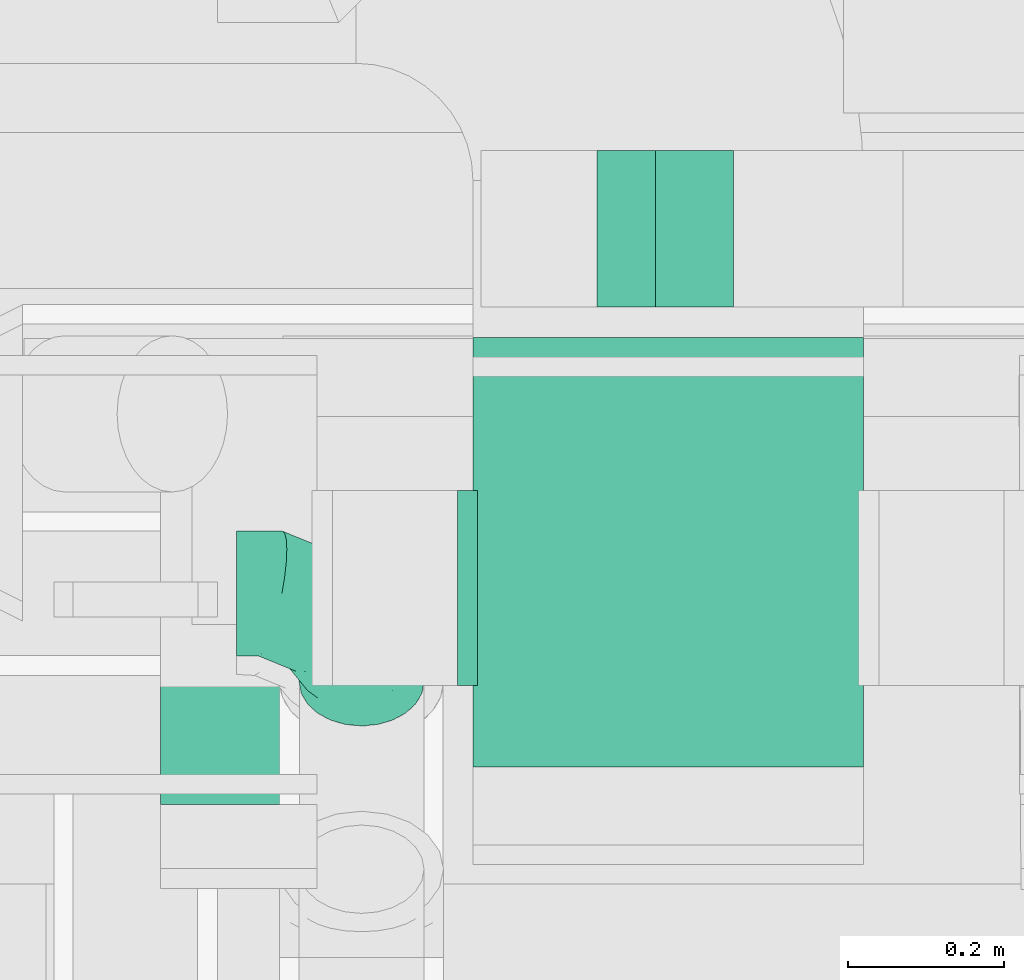
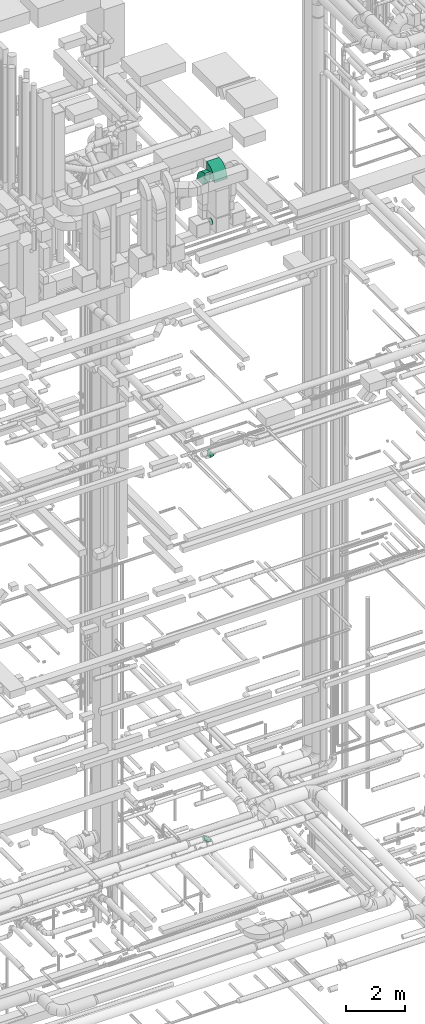
# One storey, part 233 of 337: 5 flow fittings.
"""IFC2X3 building model written with IfcOpenShell, lengths in millimetres."""

from ifc_helpers import new_model, entity, si_unit, converted_unit, derived_unit, direction, frame, frame_2d, origin, place, context, subcontext, project, spatial, polyline, circle_curve, parameter, trimmed, segment, composite_curve, outline, extrude, faceted_brep, source, transform, mapped, material, type_object, type_shapes, element, save


model = new_model("IFC2X3")

# Units and contexts
model_context = context("Model", 3, precision=0.01, world=origin(), true_north=direction((6.12303176911189e-17, 1.0)))
body_context = subcontext(model_context, "Body", "Model", "MODEL_VIEW")
ifc_project = project(units=[si_unit("LENGTHUNIT", "METRE", prefix="MILLI"), si_unit("AREAUNIT", "SQUARE_METRE"), si_unit("VOLUMEUNIT", "CUBIC_METRE"), converted_unit("PLANEANGLEUNIT", "DEGREE", entity("IfcRatioMeasure", 0.0174532925199433), si_unit("PLANEANGLEUNIT", "RADIAN"), dimensions=[0, 0, 0, 0, 0, 0, 0]), si_unit("MASSUNIT", "GRAM", prefix="KILO"), derived_unit("MASSDENSITYUNIT", [(si_unit("MASSUNIT", "GRAM", prefix="KILO"), 1), (si_unit("LENGTHUNIT", "METRE"), -3)]), derived_unit("MOMENTOFINERTIAUNIT", [(si_unit("LENGTHUNIT", "METRE"), 4)]), si_unit("TIMEUNIT", "SECOND"), si_unit("FREQUENCYUNIT", "HERTZ"), si_unit("THERMODYNAMICTEMPERATUREUNIT", "DEGREE_CELSIUS"), derived_unit("THERMALTRANSMITTANCEUNIT", [(si_unit("MASSUNIT", "GRAM", prefix="KILO"), 1), (si_unit("THERMODYNAMICTEMPERATUREUNIT", "KELVIN"), -1), (si_unit("TIMEUNIT", "SECOND"), -3)]), derived_unit("VOLUMETRICFLOWRATEUNIT", [(si_unit("LENGTHUNIT", "METRE"), 3), (si_unit("TIMEUNIT", "SECOND"), -1)]), derived_unit("MASSFLOWRATEUNIT", [(si_unit("MASSUNIT", "GRAM", prefix="KILO"), 1), (si_unit("TIMEUNIT", "SECOND"), -1)]), derived_unit("ROTATIONALFREQUENCYUNIT", [(si_unit("TIMEUNIT", "SECOND"), -1)]), si_unit("ELECTRICCURRENTUNIT", "AMPERE"), si_unit("ELECTRICVOLTAGEUNIT", "VOLT"), si_unit("POWERUNIT", "WATT"), si_unit("FORCEUNIT", "NEWTON", prefix="KILO"), si_unit("ILLUMINANCEUNIT", "LUX"), si_unit("LUMINOUSFLUXUNIT", "LUMEN"), si_unit("LUMINOUSINTENSITYUNIT", "CANDELA"), derived_unit("USERDEFINED", [(si_unit("MASSUNIT", "GRAM", prefix="KILO"), -1), (si_unit("LENGTHUNIT", "METRE"), -2), (si_unit("TIMEUNIT", "SECOND"), 3), (si_unit("LUMINOUSFLUXUNIT", "LUMEN"), 1)]), derived_unit("LINEARVELOCITYUNIT", [(si_unit("LENGTHUNIT", "METRE"), 1), (si_unit("TIMEUNIT", "SECOND"), -1)]), si_unit("PRESSUREUNIT", "PASCAL"), derived_unit("USERDEFINED", [(si_unit("LENGTHUNIT", "METRE"), -2), (si_unit("MASSUNIT", "GRAM", prefix="KILO"), 1), (si_unit("TIMEUNIT", "SECOND"), -2)]), derived_unit("LINEARFORCEUNIT", [(si_unit("MASSUNIT", "GRAM", prefix="KILO"), 1), (si_unit("LENGTHUNIT", "METRE"), 1), (si_unit("TIMEUNIT", "SECOND"), -2), (si_unit("LENGTHUNIT", "METRE"), -1)]), derived_unit("PLANARFORCEUNIT", [(si_unit("MASSUNIT", "GRAM", prefix="KILO"), 1), (si_unit("LENGTHUNIT", "METRE"), 1), (si_unit("TIMEUNIT", "SECOND"), -2), (si_unit("LENGTHUNIT", "METRE"), -2)])], contexts=[model_context])

# Site, building, storey
site_placement = place(None, origin())
site = spatial("IfcSite", under=ifc_project, at=site_placement, CompositionType="ELEMENT")
building_placement = place(site_placement, origin())
building = spatial("IfcBuilding", under=site, at=building_placement, CompositionType="ELEMENT")
storey_placement = place(building_placement, origin())
storey = spatial("IfcBuildingStorey", under=building, at=storey_placement, CompositionType="ELEMENT", Elevation=0.0)

# Flow fittings
ifc_material = material()
duct_fitting_type_1 = type_object("IfcDuctFittingType", PredefinedType="NOTDEFINED", material=ifc_material)
shared_shape_1 = source(origin(), body_context, "Body", "Brep", [
    faceted_brep([(-160.0, 0.0, -80.0), (-160.0, -20.71, -77.27), (-160.0, -40.0, -69.28), (-160.0, -56.57, -56.57), (-160.0, -69.28, -40.0), (-160.0, -77.27, -20.71), (-160.0, -80.0, 0.0), (-160.0, -77.27, 20.71), (-160.0, -69.28, 40.0), (-160.0, -56.57, 56.57), (-160.0, -40.0, 69.28), (-160.0, -20.71, 77.27), (-160.0, 0.0, 80.0), (-160.0, 20.71, 77.27), (-160.0, 40.0, 69.28), (-160.0, 56.57, 56.57), (-160.0, 69.28, 40.0), (-160.0, 77.27, 20.71), (-160.0, 80.0, 0.0), (-160.0, 77.27, -20.71), (-160.0, 69.28, -40.0), (-160.0, 56.57, -56.57), (-160.0, 40.0, -69.28), (-160.0, 20.71, -77.27), (-122.68, 20.71, 77.27), (-127.85, 40.0, 69.28), (-117.13, 0.0, 80.0), (-132.29, 56.57, 56.57), (-137.83, 77.27, 20.71), (-138.56, 80.0, 0.0), (-135.69, 69.28, 40.0), (-135.69, 69.28, -40.0), (-132.29, 56.57, -56.57), (-137.83, 77.27, -20.71), (-122.68, 20.71, -77.27), (-117.13, 0.0, -80.0), (-127.85, 40.0, -69.28), (-111.58, -20.71, -77.27), (-106.41, -40.0, -69.28), (-101.97, -56.57, -56.57), (-98.56, -69.28, -40.0), (-96.42, -77.27, -20.71), (-95.69, -80.0, 0.0), (-96.42, -77.27, 20.71), (-98.56, -69.28, 40.0), (-101.97, -56.57, 56.57), (-106.41, -40.0, 69.28), (-111.58, -20.71, 77.27), (-58.03, 58.03, 77.27), (-72.15, 72.15, 69.28), (-42.87, 42.87, 80.0), (-84.28, 84.28, 56.57), (-93.59, 93.59, 40.0), (-99.44, 99.44, 20.71), (-101.44, 101.44, 0.0), (-99.44, 99.44, -20.71), (-93.59, 93.59, -40.0), (-84.28, 84.28, -56.57), (-58.03, 58.03, -77.27), (-42.87, 42.87, -80.0), (-72.15, 72.15, -69.28), (-27.71, 27.71, -77.27), (-13.59, 13.59, -69.28), (-1.46, 1.46, -56.57), (7.85, -7.85, -40.0), (13.7, -13.7, -20.71), (15.69, -15.69, 0.0), (13.7, -13.7, 20.71), (7.85, -7.85, 40.0), (-1.46, 1.46, 56.57), (-13.59, 13.59, 69.28), (-27.71, 27.71, 77.27), (-20.71, 122.68, 77.27), (-40.0, 127.85, 69.28), (0.0, 117.13, 80.0), (-56.57, 132.29, 56.57), (-69.28, 135.69, 40.0), (-77.27, 137.83, 20.71), (-80.0, 138.56, 0.0), (-77.27, 137.83, -20.71), (-69.28, 135.69, -40.0), (-56.57, 132.29, -56.57), (-20.71, 122.68, -77.27), (0.0, 117.13, -80.0), (-40.0, 127.85, -69.28), (20.71, 111.58, -77.27), (40.0, 106.41, -69.28), (56.57, 101.97, -56.57), (69.28, 98.56, -40.0), (77.27, 96.42, -20.71), (80.0, 95.69, 0.0), (77.27, 96.42, 20.71), (69.28, 98.56, 40.0), (56.57, 101.97, 56.57), (40.0, 106.41, 69.28), (20.71, 111.58, 77.27), (-20.71, 160.0, -77.27), (-40.0, 160.0, -69.28), (-56.57, 160.0, -56.57), (-69.28, 160.0, -40.0), (-77.27, 160.0, -20.71), (-80.0, 160.0, 0.0), (-77.27, 160.0, 20.71), (-69.28, 160.0, 40.0), (-56.57, 160.0, 56.57), (-40.0, 160.0, 69.28), (-20.71, 160.0, 77.27), (0.0, 160.0, 80.0), (20.71, 160.0, 77.27), (40.0, 160.0, 69.28), (56.57, 160.0, 56.57), (69.28, 160.0, 40.0), (77.27, 160.0, 20.71), (80.0, 160.0, 0.0), (77.27, 160.0, -20.71), (69.28, 160.0, -40.0), (56.57, 160.0, -56.57), (40.0, 160.0, -69.28), (20.71, 160.0, -77.27), (0.0, 160.0, -80.0)], [[[0, 1, 2, 3, 4, 5, 6, 7, 8, 9, 10, 11, 12, 13, 14, 15, 16, 17, 18, 19, 20, 21, 22, 23]], [[24, 25, 14, 13]], [[26, 24, 13, 12]], [[14, 25, 27, 15]], [[28, 29, 18, 17]], [[30, 28, 17, 16]], [[15, 27, 30, 16]], [[20, 31, 32, 21]], [[33, 31, 20, 19]], [[18, 29, 33, 19]], [[34, 35, 0, 23]], [[36, 34, 23, 22]], [[32, 36, 22, 21]], [[1, 0, 35, 37]], [[2, 1, 37, 38]], [[3, 2, 38, 39]], [[5, 4, 40, 41]], [[6, 5, 41, 42]], [[39, 40, 4, 3]], [[6, 42, 43, 7]], [[7, 43, 44, 8]], [[8, 44, 45, 9]], [[9, 45, 46, 10]], [[10, 46, 47, 11]], [[26, 12, 11, 47]], [[48, 49, 25, 24]], [[50, 48, 24, 26]], [[27, 25, 49, 51]], [[52, 53, 28, 30]], [[51, 52, 30, 27]], [[29, 28, 53, 54]], [[55, 56, 31, 33]], [[54, 55, 33, 29]], [[32, 31, 56, 57]], [[58, 59, 35, 34]], [[60, 58, 34, 36]], [[57, 60, 36, 32]], [[37, 35, 59, 61]], [[38, 37, 61, 62]], [[39, 38, 62, 63]], [[41, 40, 64, 65]], [[42, 41, 65, 66]], [[63, 64, 40, 39]], [[43, 42, 66, 67]], [[44, 43, 67, 68]], [[68, 69, 45, 44]], [[46, 45, 69, 70]], [[47, 46, 70, 71]], [[26, 47, 71, 50]], [[72, 73, 49, 48]], [[74, 72, 48, 50]], [[51, 49, 73, 75]], [[76, 77, 53, 52]], [[75, 76, 52, 51]], [[54, 53, 77, 78]], [[79, 80, 56, 55]], [[78, 79, 55, 54]], [[57, 56, 80, 81]], [[82, 83, 59, 58]], [[84, 82, 58, 60]], [[81, 84, 60, 57]], [[61, 59, 83, 85]], [[62, 61, 85, 86]], [[63, 62, 86, 87]], [[65, 64, 88, 89]], [[66, 65, 89, 90]], [[87, 88, 64, 63]], [[67, 66, 90, 91]], [[68, 67, 91, 92]], [[92, 93, 69, 68]], [[70, 69, 93, 94]], [[71, 70, 94, 95]], [[50, 71, 95, 74]], [[96, 97, 98, 99, 100, 101, 102, 103, 104, 105, 106, 107, 108, 109, 110, 111, 112, 113, 114, 115, 116, 117, 118, 119]], [[72, 74, 107, 106]], [[73, 72, 106, 105]], [[75, 73, 105, 104]], [[77, 76, 103, 102]], [[78, 77, 102, 101]], [[75, 104, 103, 76]], [[78, 101, 100, 79]], [[79, 100, 99, 80]], [[80, 99, 98, 81]], [[84, 97, 96, 82]], [[82, 96, 119, 83]], [[84, 81, 98, 97]], [[118, 117, 86, 85]], [[119, 118, 85, 83]], [[116, 87, 86, 117]], [[88, 115, 114, 89]], [[89, 114, 113, 90]], [[115, 88, 87, 116]], [[112, 111, 92, 91]], [[113, 112, 91, 90]], [[111, 110, 93, 92]], [[95, 94, 109, 108]], [[74, 95, 108, 107]], [[110, 109, 94, 93]]]),
])
type_shapes(duct_fitting_type_1, [shared_shape_1])
flow_fitting_1_placement = place(storey_placement, frame((61727.4, 9108.65, 3500.03), z_axis=(1.21876328052369e-06, -0.707106781186021, 0.707106781186023), x_axis=(0.0, 0.707106781186549, 0.707106781186547)))
element("IfcFlowFitting", 1, at=flow_fitting_1_placement, inside=storey, type_object=duct_fitting_type_1, material=ifc_material, context=body_context, shape_type="MappedRepresentation", body=[
    mapped(shared_shape_1, transform((0.0, 0.0, 0.0), scale=1.0)),
])
duct_fitting_type_2 = type_object("IfcDuctFittingType", PredefinedType="NOTDEFINED", material=ifc_material)
shared_shape_2 = source(origin(), body_context, "Body", "Brep", [
    faceted_brep([(20.0, 0.0, -125.0), (20.0, 32.35, -120.74), (20.0, 62.5, -108.25), (20.0, 88.39, -88.39), (20.0, 108.25, -62.5), (20.0, 120.74, -32.35), (20.0, 125.0, 0.0), (20.0, 120.74, 32.35), (20.0, 108.25, 62.5), (20.0, 88.39, 88.39), (20.0, 62.5, 108.25), (20.0, 32.35, 120.74), (20.0, 0.0, 125.0), (20.0, -32.35, 120.74), (20.0, -62.5, 108.25), (20.0, -88.39, 88.39), (20.0, -108.25, 62.5), (20.0, -120.74, 32.35), (20.0, -125.0, 0.0), (20.0, -120.74, -32.35), (20.0, -108.25, -62.5), (20.0, -88.39, -88.39), (20.0, -62.5, -108.25), (20.0, -32.35, -120.74), (0.0, 0.0, 125.0), (-6.1, 0.0, 125.0), (-6.1, -32.35, 120.74), (0.0, -32.35, 120.74), (-6.1, -62.5, 108.25), (0.0, -62.5, 108.25), (0.0, -88.39, 88.39), (-6.1, -88.39, 88.39), (0.0, -108.25, 62.5), (-6.1, -108.25, 62.5), (-6.1, -120.74, 32.35), (0.0, -120.74, 32.35), (-6.1, -125.0, 0.0), (0.0, -125.0, 0.0), (-6.1, -120.74, -32.35), (0.0, -120.74, -32.35), (-6.1, -108.25, -62.5), (0.0, -108.25, -62.5), (0.0, -88.39, -88.39), (-6.1, -88.39, -88.39), (0.0, -62.5, -108.25), (-6.1, -62.5, -108.25), (-6.1, -32.35, -120.74), (0.0, -32.35, -120.74), (-6.1, 0.0, -125.0), (0.0, 0.0, -125.0), (-6.1, 32.35, -120.74), (0.0, 32.35, -120.74), (-6.1, 62.5, -108.25), (0.0, 62.5, -108.25), (0.0, 88.39, -88.39), (-6.1, 88.39, -88.39), (0.0, 108.25, -62.5), (-6.1, 108.25, -62.5), (-6.1, 120.74, -32.35), (0.0, 120.74, -32.35), (-6.1, 125.0, 0.0), (0.0, 125.0, 0.0), (-6.1, 120.74, 32.35), (0.0, 120.74, 32.35), (-6.1, 108.25, 62.5), (0.0, 108.25, 62.5), (0.0, 88.39, 88.39), (-6.1, 88.39, 88.39), (0.0, 62.5, 108.25), (-6.1, 62.5, 108.25), (-6.1, 32.35, 120.74), (0.0, 32.35, 120.74)], [[[0, 1, 2, 3, 4, 5, 6, 7, 8, 9, 10, 11, 12, 13, 14, 15, 16, 17, 18, 19, 20, 21, 22, 23]], [[13, 12, 24, 25, 26, 27]], [[14, 13, 27, 26, 28, 29]], [[30, 15, 14, 29, 28, 31]], [[17, 16, 32, 33, 34, 35]], [[18, 17, 35, 34, 36, 37]], [[32, 16, 15, 30, 31, 33]], [[19, 18, 37, 36, 38, 39]], [[20, 19, 39, 38, 40, 41]], [[42, 21, 20, 41, 40, 43]], [[23, 22, 44, 45, 46, 47]], [[0, 23, 47, 46, 48, 49]], [[44, 22, 21, 42, 43, 45]], [[1, 0, 49, 48, 50, 51]], [[2, 1, 51, 50, 52, 53]], [[54, 3, 2, 53, 52, 55]], [[5, 4, 56, 57, 58, 59]], [[6, 5, 59, 58, 60, 61]], [[56, 4, 3, 54, 55, 57]], [[7, 6, 61, 60, 62, 63]], [[8, 7, 63, 62, 64, 65]], [[66, 9, 8, 65, 64, 67]], [[11, 10, 68, 69, 70, 71]], [[12, 11, 71, 70, 25, 24]], [[68, 10, 9, 66, 67, 69]], [[46, 45, 43, 40, 38, 36, 34, 33, 31, 28, 26, 25, 70, 69, 67, 64, 62, 60, 58, 57, 55, 52, 50, 48]]]),
])
type_shapes(duct_fitting_type_2, [shared_shape_2])
flow_fitting_2_placement = place(storey_placement, frame((61870.03, 9115.48, 28740.0), z_axis=(0.0, 0.0, -1.0), x_axis=(-1.0, 0.0, 0.0)))
element("IfcFlowFitting", 2, at=flow_fitting_2_placement, inside=storey, type_object=duct_fitting_type_2, material=ifc_material, context=body_context, shape_type="MappedRepresentation", body=[
    mapped(shared_shape_2, transform((0.0, 0.0, 0.0), scale=1.0)),
])
duct_fitting_type_3 = type_object("IfcDuctFittingType", PredefinedType="NOTDEFINED", material=ifc_material)
shared_shape_3 = source(origin(), body_context, "Body", "SweptSolid", [
    extrude(outline(composite_curve([segment(polyline([(-375.0, -175.0), (25.0, -175.0)]), True, "CONTINUOUS"), segment(trimmed(circle_curve(frame_2d((175.0, -175.0), x_axis=(0.0, 1.0)), 150.0), [parameter(0.0)], [parameter(90.0000000000001)], True, "PARAMETER"), False, "CONTINUOUS"), segment(polyline([(175.0, -25.0), (175.0, 375.0)]), True, "CONTINUOUS"), segment(trimmed(circle_curve(frame_2d((175.0, -175.0), x_axis=(0.0, 1.0)), 550.0), [parameter(0.0)], [parameter(90.0)], True, "PARAMETER"), True, "CONTINUOUS")], self_intersect=False)), frame((-175.0, 175.0, -100.0), z_axis=(0.0, 0.0, 1.0), x_axis=(-1.0, 0.0, 0.0)), (0.0, 0.0, 1.0), 200.0),
])
type_shapes(duct_fitting_type_3, [shared_shape_3])
flow_fitting_3_placement = place(storey_placement, frame((61570.03, 9188.6, 30800.0), z_axis=(1.0, 0.0, 0.0), x_axis=(0.0, 0.0, 1.0)))
element("IfcFlowFitting", 3, at=flow_fitting_3_placement, inside=storey, type_object=duct_fitting_type_3, material=ifc_material, context=body_context, shape_type="MappedRepresentation", body=[
    mapped(shared_shape_3, transform((0.0, 0.0, 0.0), scale=1.0)),
])
duct_fitting_type_4 = type_object("IfcDuctFittingType", PredefinedType="NOTDEFINED", material=ifc_material)
shared_shape_4 = source(origin(), body_context, "Body", "SweptSolid", [
    extrude(outline(composite_curve([segment(polyline([(-116.75, -62.5), (83.25, -62.5)]), True, "CONTINUOUS"), segment(trimmed(circle_curve(frame_2d((233.25, -62.5), x_axis=(-0.866024970770717, 0.500000750001014)), 150.0), [parameter(0.0)], [parameter(30.0000496196802)], True, "PARAMETER"), False, "CONTINUOUS"), segment(polyline([(103.35, 12.5), (-69.86, 112.5)]), True, "CONTINUOUS"), segment(trimmed(circle_curve(frame_2d((233.25, -62.5), x_axis=(-0.866024970770717, 0.500000750001014)), 350.0), [parameter(0.0)], [parameter(30.0000496196802)], True, "PARAMETER"), True, "CONTINUOUS")], self_intersect=False)), frame((-4.49, 16.75, -100.0), z_axis=(0.0, 0.0, 1.0), x_axis=(-0.500000750001015, 0.866024970770718, 0.0)), (0.0, 0.0, 1.0), 200.0),
])
type_shapes(duct_fitting_type_4, [shared_shape_4])
flow_fitting_4_placement = place(storey_placement, frame((62095.78, 9575.53, 18850.0), z_axis=(0.0, -1.0, 0.0), x_axis=(1.0, 0.0, 0.0)))
element("IfcFlowFitting", 4, at=flow_fitting_4_placement, inside=storey, type_object=duct_fitting_type_4, material=ifc_material, context=body_context, shape_type="MappedRepresentation", body=[
    mapped(shared_shape_4, transform((0.0, 0.0, 0.0), scale=1.0)),
])
duct_fitting_type_5 = type_object("IfcDuctFittingType", PredefinedType="NOTDEFINED", material=ifc_material)
shared_shape_5 = source(origin(), body_context, "Body", "SweptSolid", [
    extrude(outline(composite_curve([segment(polyline([(-375.0, -175.0), (25.0, -175.0)]), True, "CONTINUOUS"), segment(trimmed(circle_curve(frame_2d((175.0, -175.0), x_axis=(2.48384139922564e-08, 1.0)), 150.0), [parameter(0.0)], [parameter(90.0000014231355)], True, "PARAMETER"), False, "CONTINUOUS"), segment(polyline([(175.0, -25.0), (175.0, 375.0)]), True, "CONTINUOUS"), segment(trimmed(circle_curve(frame_2d((175.0, -175.0), x_axis=(2.48384139922564e-08, 1.0)), 550.0), [parameter(0.0)], [parameter(90.0000014231355)], True, "PARAMETER"), True, "CONTINUOUS")], self_intersect=False)), frame((-175.0, 175.0, -250.0), z_axis=(0.0, 0.0, 1.0), x_axis=(-1.0, -2.48383991214851e-08, 0.0)), (0.0, 0.0, 1.0), 500.0),
])
type_shapes(duct_fitting_type_5, [shared_shape_5])
flow_fitting_5_placement = place(storey_placement, frame((62120.03, 9086.6, 30800.0), z_axis=(-1.0, 0.0, 0.0), x_axis=(0.0, 0.0, 1.0)))
element("IfcFlowFitting", 5, at=flow_fitting_5_placement, inside=storey, type_object=duct_fitting_type_5, material=ifc_material, context=body_context, shape_type="MappedRepresentation", body=[
    mapped(shared_shape_5, transform((0.0, 0.0, 0.0), scale=1.0)),
])

save(model, "model.ifc")
